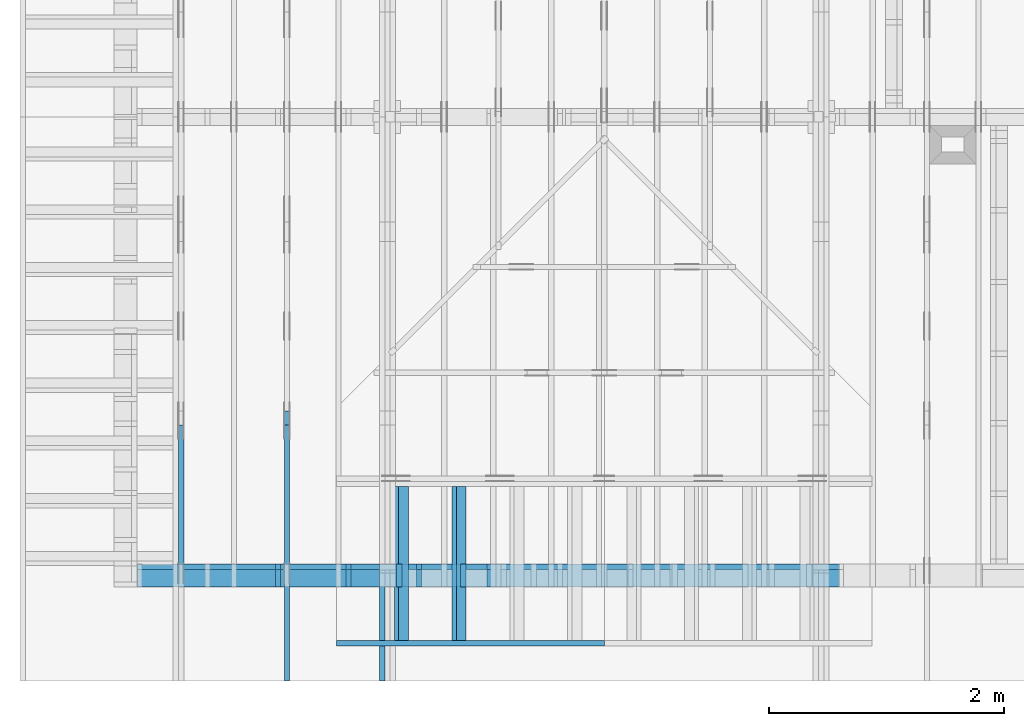
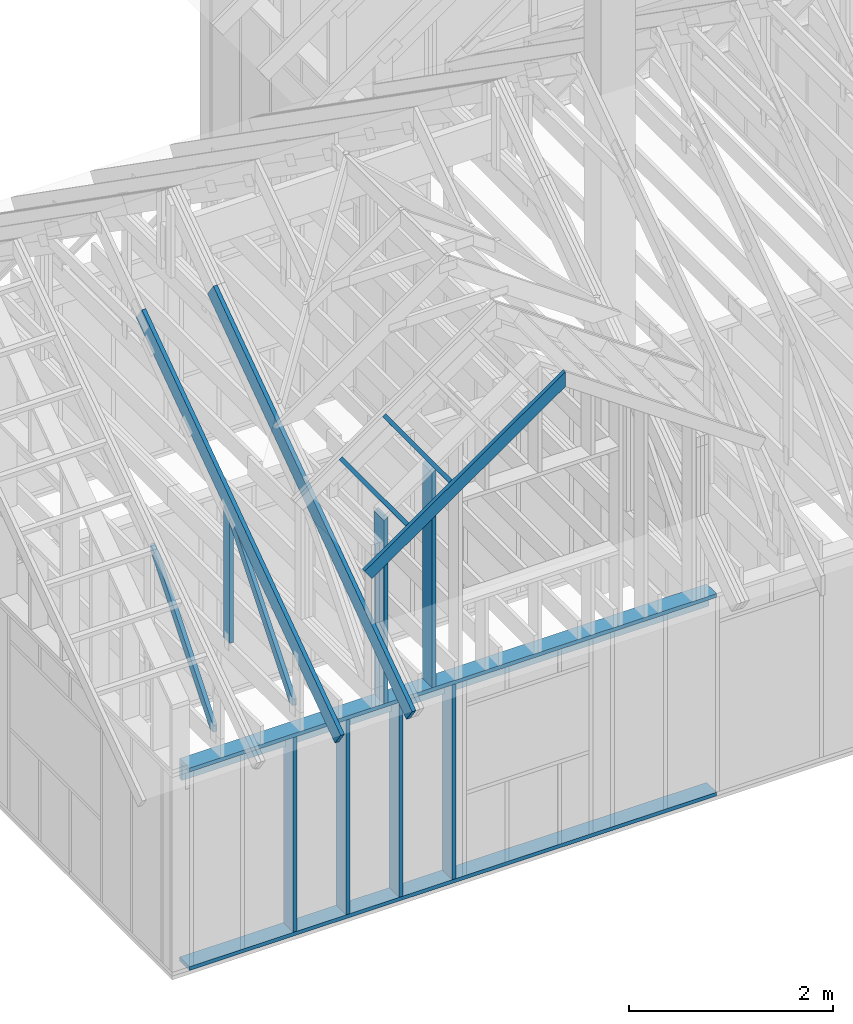
# One storey, part 3 of 70: 17 members, 6 elements without a shape of their own.
"""IFC2X3 building model written with IfcOpenShell, lengths in millimetres."""

from ifc_helpers import new_model, si_unit, frame, origin, origin_with_axes, origin_2d, place, context, project, spatial, faceted_brep, element, aggregate, save


model = new_model("IFC2X3")

# Units and contexts
model_context = context("Model", 3, precision=1e-05, world=origin())
plan_context = context("Plan", 2, precision=1e-05, world=origin_2d())
ifc_project = project(units=[si_unit("LENGTHUNIT", "METRE", prefix="MILLI"), si_unit("AREAUNIT", "SQUARE_METRE"), si_unit("VOLUMEUNIT", "CUBIC_METRE"), si_unit("SOLIDANGLEUNIT", "STERADIAN"), si_unit("PLANEANGLEUNIT", "RADIAN"), si_unit("MASSUNIT", "GRAM"), si_unit("TIMEUNIT", "SECOND"), si_unit("THERMODYNAMICTEMPERATUREUNIT", "DEGREE_CELSIUS"), si_unit("LUMINOUSINTENSITYUNIT", "LUMEN")], contexts=[model_context, plan_context])

# Site, building, storey
site_placement = place(None, origin_with_axes())
site = spatial("IfcSite", under=ifc_project, at=site_placement, CompositionType="ELEMENT")
building_placement = place(site_placement, origin_with_axes())
building = spatial("IfcBuilding", under=site, at=building_placement, Name="Layout 1", CompositionType="ELEMENT")
storey_placement = place(building_placement, origin_with_axes())
storey = spatial("IfcBuildingStorey", under=building, at=storey_placement, Name="Storey 1", CompositionType="ELEMENT", Elevation=0.0)

# Assembly, member
assembly_1_placement = place(storey_placement, frame((1969.9999999999982, 8000.000000000001, 1.1021457184401395e-14), z_axis=(-1.0, 1.836909530733566e-16, 6.123031769111886e-17), x_axis=(-1.836909530733566e-16, -1.0, 0.0)))
assembly_1 = element("IfcElementAssembly", 1, at=assembly_1_placement, inside=storey, Name="T11", AssemblyPlace="FACTORY", PredefinedType="TRUSS")
member_1_placement = place(assembly_1_placement, frame((4782.309641268, 3014.9999999994516, -90.00000000000001), z_axis=(0.0, 0.0, 1.0), x_axis=(0.8191520442889916, -0.5735764363510465, 0.0)))
member_1 = element("IfcMember", 2, at=member_1_placement, Name="T9", context=model_context, shape_type="Brep", body=[
    faceted_brep([(4768.153825500908, 195.00000000180353, 45.0), (1.6370904631912708e-10, 195.00000000180353, 45.0), (0.0, 1.8071659724228084e-09, 45.0), (4768.153825500287, 1.8071659724228084e-09, 45.0), (1.6370904631912708e-10, 195.00000000180353, 2.004791383006049e-26), (4768.153825500908, 195.00000000180353, 5.839111470710887e-13), (4768.153825500287, 1.8071659724228084e-09, 5.839111470710126e-13), (0.0, 1.8071659724228084e-09, 0.0), (-1.2523674699591298e-25, 1.8071659724228084e-09, 7.668285805162028e-42), (2.755364295975112e-15, 1.8071659724228084e-09, 45.0), (1.636957134777711e-10, 195.000000001015, 45.0), (1.63692958113475e-10, 195.000000001015, 9.850859431565386e-31), (4768.153825500287, -2.042652045517506e-12, 1.250722336794479e-28), (4768.153825500287, -2.039896681221406e-12, 45.0), (1.0454840658689129e-27, 1.8071687277871045e-09, 45.0), (0.0, 1.8071659724228084e-09, 0.0), (4768.153825500287, 195.00000000180353, -3.8067271842345146e-26), (4768.153825500287, 195.00000000180353, 45.0), (4768.153825500287, 0.0, 45.0), (4768.153825500287, 0.0, 0.0), (1.6370904631912708e-10, 195.000000001015, 0.0), (1.6370904631912708e-10, 195.000000001015, 45.0), (4768.153825500908, 195.00000000180347, 45.0), (4768.153825500908, 195.00000000180347, -4.733165431326071e-30)], [[[0, 1, 2, 3]], [[4, 5, 6, 7]], [[8, 9, 10, 11]], [[12, 13, 14, 15]], [[16, 17, 18, 19]], [[20, 21, 22, 23]]]),
])
aggregate(assembly_1, [member_1])

assembly_2_placement = place(storey_placement, frame((304.9999999999989, 8000.000000000001, 1.3776821480501744e-15), z_axis=(-1.0, 1.836909530733566e-16, 6.123031769111886e-17), x_axis=(-1.836909530733566e-16, -1.0, 0.0)))
assembly_2 = element("IfcElementAssembly", 3, at=assembly_2_placement, inside=storey, Name="T2", AssemblyPlace="FACTORY", PredefinedType="TRUSS")
member_2_placement = place(assembly_2_placement, frame((6583.248845012375, 1698.1421260061566, -45.00000000000001), z_axis=(0.0, 0.0, 1.0), x_axis=(0.6335417245359882, -0.7737085260432164, 0.0)))
member_2 = element("IfcMember", 4, at=member_2_placement, Name="W7", context=model_context, shape_type="Brep", body=[
    faceted_brep([(1891.3495332787188, 95.00000000000091, 45.0), (169.12158093146445, 95.00000000000091, 45.0), (0.0, 47.4999999999518, 45.0), (58.00905222766687, 0.0, 45.0), (1910.4637938597489, 0.0, 45.0), (1949.3585855061046, 47.4999999999518, 45.0), (169.12158093146445, 95.00000000000091, 2.0710736257715677e-14), (1891.3495332787188, 95.00000000000091, 2.316158655752107e-13), (1949.3585855061046, 47.4999999999518, 2.3871969096889775e-13), (1910.4637938597489, 0.0, 2.339566100708253e-13), (58.00905222766687, 0.0, 7.103825393721498e-15), (0.0, 47.4999999999518, 0.0), (-1.7763568394002505e-15, 47.4999999999518, 0.0), (-1.7763568394002505e-15, 47.4999999999518, 45.0), (169.12158093146445, 94.9999999999991, 45.0), (169.12158093146445, 94.9999999999991, 7.888609052210118e-31), (58.009052227666864, -1.0658141036401503e-14, 7.888609052210118e-31), (58.009052227666864, -7.105427357601002e-15, 45.0), (7.105427357601002e-15, 47.49999999995181, 45.0), (7.105427357601002e-15, 47.49999999995181, -7.888609052210118e-31), (1910.4637938597489, 1.2889367027916569e-12, 3.24552952602152e-29), (1910.4637938597489, 1.2916920670877572e-12, 45.0), (58.00905222766687, -1.3339080885373479e-14, 45.0), (58.00905222766687, -1.6094445181473828e-14, 9.854679915239394e-31), (1949.3585855061056, 47.50000000000102, 6.310887241768094e-29), (1949.3585855061056, 47.50000000000102, 45.0), (1910.4637938597493, 9.094947017729282e-13, 45.0), (1910.4637938597493, 9.094947017729282e-13, 6.310887241768094e-29), (1891.3495332787193, 95.00000000000114, 2.524354896707238e-29), (1891.3495332787193, 95.00000000000114, 45.0), (1949.358585506105, 47.500000000002046, 45.0), (1949.358585506105, 47.500000000002046, 2.524354896707238e-29), (169.12158093146445, 94.99999999999908, 0.0), (169.12158093146445, 94.99999999999908, 45.0), (1891.3495332787188, 95.00000000000088, 45.0), (1891.3495332787188, 95.0000000000009, -1.5777218104420236e-30)], [[[0, 1, 2, 3, 4, 5]], [[6, 7, 8, 9, 10, 11]], [[12, 13, 14, 15]], [[16, 17, 18, 19]], [[20, 21, 22, 23]], [[24, 25, 26, 27]], [[28, 29, 30, 31]], [[32, 33, 34, 35]]]),
])
aggregate(assembly_2, [member_2])

# Assembly, members
assembly_3_placement = place(storey_placement, frame((1204.9999999999989, 8000.000000000001, 1.3776821480501744e-15), z_axis=(-1.0, 1.836909530733566e-16, 6.123031769111886e-17), x_axis=(-1.836909530733566e-16, -1.0, 0.0)))
assembly_3 = element("IfcElementAssembly", 5, at=assembly_3_placement, inside=storey, Name="T2", AssemblyPlace="FACTORY", PredefinedType="TRUSS")
member_3_placement = place(assembly_3_placement, frame((4782.309641268, 3014.9999999994516, -45.00000000000001), z_axis=(0.0, 0.0, 1.0), x_axis=(0.8191520442889916, -0.5735764363510465, 0.0)))
member_3 = element("IfcMember", 6, at=member_3_placement, Name="T9", context=model_context, shape_type="Brep", body=[
    faceted_brep([(4768.153825500908, 195.00000000180353, 45.0), (1.6370904631912708e-10, 195.00000000180353, 45.0), (0.0, 1.8071659724228084e-09, 45.0), (4768.153825500287, 1.8071659724228084e-09, 45.0), (1.6370904631912708e-10, 195.00000000180353, 2.004791383006049e-26), (4768.153825500908, 195.00000000180353, 5.839111470710887e-13), (4768.153825500287, 1.8071659724228084e-09, 5.839111470710126e-13), (0.0, 1.8071659724228084e-09, 0.0), (-1.2523674699591298e-25, 1.8071659724228084e-09, 7.668285805162028e-42), (2.755364295975112e-15, 1.8071659724228084e-09, 45.0), (1.636957134777711e-10, 195.000000001015, 45.0), (1.63692958113475e-10, 195.000000001015, 9.850859431565386e-31), (4768.153825500287, -2.042652045517506e-12, 1.250722336794479e-28), (4768.153825500287, -2.039896681221406e-12, 45.0), (1.0454840658689129e-27, 1.8071687277871045e-09, 45.0), (0.0, 1.8071659724228084e-09, 0.0), (4768.153825500287, 195.00000000180353, -3.8067271842345146e-26), (4768.153825500287, 195.00000000180353, 45.0), (4768.153825500287, 0.0, 45.0), (4768.153825500287, 0.0, 0.0), (1.6370904631912708e-10, 195.000000001015, 0.0), (1.6370904631912708e-10, 195.000000001015, 45.0), (4768.153825500908, 195.00000000180347, 45.0), (4768.153825500908, 195.00000000180347, -4.733165431326071e-30)], [[[0, 1, 2, 3]], [[4, 5, 6, 7]], [[8, 9, 10, 11]], [[12, 13, 14, 15]], [[16, 17, 18, 19]], [[20, 21, 22, 23]]]),
])
member_4_placement = place(assembly_3_placement, frame((6619.999999999389, 220.0, -45.0), z_axis=(0.0, 0.0, 1.0), x_axis=(6.123031769111886e-17, 1.0, 0.0)))
member_4 = element("IfcMember", 7, at=member_4_placement, Name="R1", context=model_context, shape_type="Brep", body=[
    faceted_brep([(1592.2602625068248, 120.0, 45.0), (0.0, 120.0, 45.0), (0.0, 1.4551915228366852e-11, 45.0), (1508.235357921585, 1.4551915228366852e-11, 45.0), (0.0, 120.0, 0.0), (1592.2602625068248, 120.0, 1.949892034404744e-13), (1508.235357921585, 1.4551915228366852e-11, 1.8469946023703405e-13), (0.0, 1.4551915228366852e-11, 0.0), (1.7820367848942657e-27, 1.4551915228366852e-11, -1.0911467847633593e-43), (2.755364296102131e-15, 1.4551915228366852e-11, 45.0), (1.7450640541968876e-14, 120.0, 45.0), (1.4695276245868527e-14, 120.0, -8.997964330932825e-31), (1508.235357921585, -4.605370260698061e-13, 2.81988284147774e-29), (1508.235357921585, -4.577816617737058e-13, 45.0), (2.7425941661909085e-29, 1.4554670592662952e-11, 45.0), (0.0, 1.4551915228366852e-11, 0.0), (1592.260262506825, 120.00000000000011, 1.262177448353619e-29), (1592.260262506825, 120.00000000000011, 45.0), (1508.2353579215853, 0.0, 45.0), (1508.2353579215853, 0.0, 1.262177448353619e-29), (0.0, 120.0, 0.0), (-1.6871183120499046e-31, 120.0, 45.0), (1592.2602625068248, 119.9999999999999, 45.0), (1592.2602625068248, 119.9999999999999, -6.310887241768095e-30)], [[[0, 1, 2, 3]], [[4, 5, 6, 7]], [[8, 9, 10, 11]], [[12, 13, 14, 15]], [[16, 17, 18, 19]], [[20, 21, 22, 23]]]),
])
member_5_placement = place(assembly_3_placement, frame((6583.248845012375, 1698.1421260061566, -45.00000000000001), z_axis=(0.0, 0.0, 1.0), x_axis=(0.6335417245359882, -0.7737085260432164, 0.0)))
member_5 = element("IfcMember", 8, at=member_5_placement, Name="W7", context=model_context, shape_type="Brep", body=[
    faceted_brep([(1891.3495332787188, 95.00000000000091, 45.0), (169.12158093146445, 95.00000000000091, 45.0), (0.0, 47.4999999999518, 45.0), (58.00905222766687, 0.0, 45.0), (1910.4637938597489, 0.0, 45.0), (1949.3585855061046, 47.4999999999518, 45.0), (169.12158093146445, 95.00000000000091, 2.0710736257715677e-14), (1891.3495332787188, 95.00000000000091, 2.316158655752107e-13), (1949.3585855061046, 47.4999999999518, 2.3871969096889775e-13), (1910.4637938597489, 0.0, 2.339566100708253e-13), (58.00905222766687, 0.0, 7.103825393721498e-15), (0.0, 47.4999999999518, 0.0), (-1.7763568394002505e-15, 47.4999999999518, 0.0), (-1.7763568394002505e-15, 47.4999999999518, 45.0), (169.12158093146445, 94.9999999999991, 45.0), (169.12158093146445, 94.9999999999991, 7.888609052210118e-31), (58.009052227666864, -1.0658141036401503e-14, 7.888609052210118e-31), (58.009052227666864, -7.105427357601002e-15, 45.0), (7.105427357601002e-15, 47.49999999995181, 45.0), (7.105427357601002e-15, 47.49999999995181, -7.888609052210118e-31), (1910.4637938597489, 1.2889367027916569e-12, 3.24552952602152e-29), (1910.4637938597489, 1.2916920670877572e-12, 45.0), (58.00905222766687, -1.3339080885373479e-14, 45.0), (58.00905222766687, -1.6094445181473828e-14, 9.854679915239394e-31), (1949.3585855061056, 47.50000000000102, 6.310887241768094e-29), (1949.3585855061056, 47.50000000000102, 45.0), (1910.4637938597493, 9.094947017729282e-13, 45.0), (1910.4637938597493, 9.094947017729282e-13, 6.310887241768094e-29), (1891.3495332787193, 95.00000000000114, 2.524354896707238e-29), (1891.3495332787193, 95.00000000000114, 45.0), (1949.358585506105, 47.500000000002046, 45.0), (1949.358585506105, 47.500000000002046, 2.524354896707238e-29), (169.12158093146445, 94.99999999999908, 0.0), (169.12158093146445, 94.99999999999908, 45.0), (1891.3495332787188, 95.00000000000088, 45.0), (1891.3495332787188, 95.0000000000009, -1.5777218104420236e-30)], [[[0, 1, 2, 3, 4, 5]], [[6, 7, 8, 9, 10, 11]], [[12, 13, 14, 15]], [[16, 17, 18, 19]], [[20, 21, 22, 23]], [[24, 25, 26, 27]], [[28, 29, 30, 31]], [[32, 33, 34, 35]]]),
])
aggregate(assembly_3, [member_3, member_4, member_5])

assembly_4_placement = place(storey_placement, frame((-48.55339059325575, 0.0, -2470.0), z_axis=(0.0, -1.0, 6.123031769111886e-17), x_axis=(1.0, 0.0, 0.0)))
assembly_4 = element("IfcElementAssembly", 9, at=assembly_4_placement, inside=storey, Name="VE4", AssemblyPlace="FACTORY", PredefinedType="NOTDEFINED")
member_6_placement = place(assembly_4_placement, frame((1.457281561048629e-13, 2425.0, -195.0), z_axis=(0.0, 0.0, 1.0), x_axis=(1.0, 0.0, 0.0)))
member_6 = element("IfcMember", 10, at=member_6_placement, Name="P1", context=model_context, shape_type="Brep", body=[
    faceted_brep([(5980.000000000002, 45.0, 195.0), (2.755364296100349e-15, 45.0, 195.0), (0.0, 0.0, 195.0), (5980.000000000002, 0.0, 195.0), (2.755364296100349e-15, 45.0, 3.3742366240998092e-31), (5980.000000000002, 45.0, 7.323145995857818e-13), (5980.000000000002, 0.0, 7.323145995857818e-13), (0.0, 0.0, 0.0), (0.0, 0.0, 0.0), (1.1939911949768178e-14, -1.462169203776584e-30, 195.0), (1.7450640541968876e-14, 45.0, 195.0), (5.510728592200698e-15, 45.0, -1.6871183120499046e-31), (5980.000000000002, -1.0984718993786728e-12, 6.725978337372289e-29), (5980.000000000002, -1.0865319874289046e-12, 195.0), (2.193253805664876e-30, 1.1939911949768178e-14, 195.0), (0.0, 0.0, 0.0), (5980.000000000002, 45.0, 0.0), (5980.000000000002, 45.0, 195.0), (5980.000000000002, 0.0, 195.0), (5980.000000000002, 0.0, 0.0), (2.755364296100349e-15, 45.0, 0.0), (2.755364296100348e-15, 44.999999999999986, 195.0), (5980.000000000002, 44.99999999999962, 195.0), (5980.000000000002, 44.99999999999963, -2.2482535798798836e-29)], [[[0, 1, 2, 3]], [[4, 5, 6, 7]], [[8, 9, 10, 11]], [[12, 13, 14, 15]], [[16, 17, 18, 19]], [[20, 21, 22, 23]]]),
])
member_7_placement = place(assembly_4_placement, frame((5980.0, 90.0, -195.0), z_axis=(0.0, 0.0, 1.0), x_axis=(-1.0, 1.2246063538223773e-16, 0.0)))
member_7 = element("IfcMember", 11, at=member_7_placement, Name="P1", context=model_context, shape_type="Brep", body=[
    faceted_brep([(5980.0, 45.00000000000074, 195.0), (0.0, 45.00000000000074, 195.0), (0.0, 0.0, 195.0), (5980.0, 0.0, 195.0), (0.0, 45.00000000000074, 0.0), (5980.0, 45.00000000000074, 7.323145995857816e-13), (5980.0, 0.0, 7.323145995857816e-13), (0.0, 0.0, 0.0), (0.0, 0.0, 0.0), (1.1939911949768178e-14, -1.462169203776584e-30, 195.0), (1.7450640541968876e-14, 45.00000000000001, 195.0), (5.5107285922006985e-15, 45.00000000000001, -3.3742366240998097e-31), (5980.0, -1.0984718993786724e-12, 1.1250681111517883e-28), (5980.0, -1.0865319874289042e-12, 195.0), (2.193253805664876e-30, 1.1939911949768178e-14, 195.0), (0.0, 0.0, 0.0), (5980.0, 45.00000000000074, 0.0), (5980.0, 45.00000000000074, 195.0), (5980.0, 7.389644451905042e-13, 195.0), (5980.0, 7.389644451905042e-13, 0.0), (0.0, 45.00000000000001, 0.0), (1.5777218104420236e-30, 44.99999999999999, 195.0), (5980.0, 45.00000000000096, 195.0), (5980.0, 45.000000000000966, 1.3805065841367707e-29)], [[[0, 1, 2, 3]], [[4, 5, 6, 7]], [[8, 9, 10, 11]], [[12, 13, 14, 15]], [[16, 17, 18, 19]], [[20, 21, 22, 23]]]),
])
member_8_placement = place(assembly_4_placement, frame((1.3378824415499132e-13, 2229.9999999981374, -195.0), z_axis=(0.0, 0.0, 1.0), x_axis=(1.0, 0.0, 0.0)))
member_8 = element("IfcMember", 12, at=member_8_placement, Name="L1", context=model_context, shape_type="Brep", body=[
    faceted_brep([(5980.000000000002, 195.00000000186265, 45.0), (1.1939911949871576e-14, 195.00000000186265, 45.0), (0.0, 0.0, 45.0), (5980.000000000002, 0.0, 45.0), (1.1939911949871576e-14, 195.00000000186265, 1.4621692037892461e-30), (5980.000000000002, 195.00000000186265, 7.323145995857818e-13), (5980.000000000002, 0.0, 7.323145995857818e-13), (0.0, 0.0, 0.0), (0.0, 0.0, 0.0), (2.755364296100349e-15, -3.3742366240998092e-31, 45.0), (2.6635188195864806e-14, 195.00000000186265, 45.0), (2.3879823899764457e-14, 195.00000000186265, -7.310846018959277e-31), (5980.000000000002, 1.8631702674827906e-09, -3.215315738519505e-29), (5980.000000000002, 1.8631730228470867e-09, 45.0), (-8.584804067855881e-28, 2.755364296100349e-15, 45.0), (0.0, 0.0, 0.0), (5980.000000000002, 195.00000000186265, 0.0), (5980.000000000002, 195.00000000186265, 45.0), (5980.000000000002, 1.862645149230957e-09, 45.0), (5980.000000000002, 1.862645149230957e-09, 0.0), (1.1939911949871576e-14, 195.00000000186265, 0.0), (1.1939911949871576e-14, 195.00000000186265, 45.0), (5980.000000000002, 195.00000000186228, 45.0), (5980.000000000002, 195.00000000186228, -2.208810534618833e-29)], [[[0, 1, 2, 3]], [[4, 5, 6, 7]], [[8, 9, 10, 11]], [[12, 13, 14, 15]], [[16, 17, 18, 19]], [[20, 21, 22, 23]]]),
])
member_9_placement = place(assembly_4_placement, frame((2977.499999992955, 2425.0, -195.0), z_axis=(0.0, 0.0, 1.0), x_axis=(7.044874666267686e-16, -1.0, 0.0)))
member_9 = element("IfcMember", 13, at=member_9_placement, Name="S11", context=model_context, shape_type="Brep", body=[
    faceted_brep([(0.0, 45.00000000000182, 45.0), (195.00000000186265, 45.00000000000182, 45.00000000000002), (195.00000000186265, 1.8189894035458565e-12, 45.00000000000002), (0.0, 1.8189894035458565e-12, 45.0), (195.00000000186265, 1.3642420526593924e-12, 0.0), (195.00000000186265, 1.3642420526593924e-12, 45.0), (195.00000000186265, 45.00000000000273, 45.0), (195.00000000186265, 45.00000000000273, 0.0), (2.7553642961005717e-15, 1.8189894035458565e-12, 45.0), (1.19399119497684e-14, 1.8189894035458565e-12, 195.0), (1.7450640541969097e-14, 45.00000000000182, 195.0), (8.266092888301269e-15, 45.00000000000182, 45.0), (2335.0, -2.757722191880016e-12, 2.8023350496855364e-28), (2335.0, -2.745782279930248e-12, 195.0), (2.340279805947236e-29, 1.8309293154956247e-12, 195.0), (5.400645706032083e-30, 1.821744767841957e-12, 45.0), (195.00000000186265, 1.4395354483059526e-12, 45.0), (195.00000000186265, 1.4367800840098523e-12, -4.441526704277007e-30), (0.0, 45.00000000000318, 45.0), (-2.524354896707238e-29, 45.00000000000317, 195.0), (2335.0, 44.99999999999785, 195.0), (2335.0, 44.999999999997854, -2.9858385262615297e-28), (195.00000000186265, 45.000000000002736, 3.944304526105059e-31), (195.00000000186265, 45.000000000002736, 45.0), (2335.0, 45.00000000001455, 0.0), (2335.0, 45.00000000001455, 195.0), (2335.0, 0.0, 195.0), (2335.0, 0.0, 0.0), (2335.0, 45.00000000001455, 195.0), (0.0, 45.00000000001455, 195.0), (0.0, 1.8189894035458565e-12, 195.0), (2335.0, 1.8189894035458565e-12, 195.0), (195.00000000186265, 45.00000000000273, 2.3879823899764457e-14), (2335.0, 45.00000000000273, 2.859455836175251e-13), (2335.0, 0.0, 2.859455836175251e-13), (195.00000000186265, 0.0, 2.3879823899764457e-14)], [[[0, 1, 2, 3]], [[4, 5, 6, 7]], [[8, 9, 10, 11]], [[12, 13, 14, 15, 16, 17]], [[18, 19, 20, 21, 22, 23]], [[24, 25, 26, 27]], [[28, 29, 30, 31]], [[32, 33, 34, 35]]]),
])
member_10_placement = place(assembly_4_placement, frame((1177.5000000018194, 2425.0, -195.0), z_axis=(0.0, 0.0, 1.0), x_axis=(-1.836909530733566e-16, -1.0, 0.0)))
member_10 = element("IfcMember", 14, at=member_10_placement, Name="S11", context=model_context, shape_type="Brep", body=[
    faceted_brep([(0.0, 44.999999999999545, 45.0), (195.00000000186265, 44.999999999999545, 45.00000000000002), (195.00000000186265, 1.4097167877480388e-11, 45.00000000000002), (0.0, 1.4097167877480388e-11, 45.0), (195.00000000186265, 1.2960299500264227e-11, 0.0), (195.00000000186265, 1.2960299500264227e-11, 45.0), (195.00000000186265, 45.00000000000068, 45.0), (195.00000000186265, 45.00000000000068, 0.0), (2.7553642961020753e-15, 1.4097167877480388e-11, 45.0), (1.1939911949769904e-14, 1.4097167877480388e-11, 195.0), (1.7450640541968822e-14, 44.999999999999545, 195.00000000000003), (8.26609288830099e-15, 44.999999999999545, 45.0), (2335.0, 1.36682495020541e-11, 2.626280839091018e-29), (2335.0, 1.3680189414003868e-11, 195.0), (2.193253805664876e-30, 1.4109107789430156e-11, 195.0), (5.061354936149714e-31, 1.4099923241776488e-11, 45.0), (195.00000000186265, 1.4064103505926841e-11, 45.0), (195.00000000186265, 1.406134814163074e-11, 2.193253805685862e-30), (-1.6871183120499046e-31, 45.00000000000068, 45.0), (-7.31084601888292e-31, 45.00000000000067, 195.0), (2335.0, 45.000000000000526, 195.0), (2335.0, 45.00000000000054, -8.67746995743113e-30), (195.00000000186265, 45.00000000000067, -7.888609052210118e-31), (195.00000000186265, 45.00000000000067, 45.0), (2335.0, 45.00000000001455, 0.0), (2335.0, 45.00000000001455, 195.0), (2335.0, 0.0, 195.0), (2335.0, 0.0, 0.0), (2335.0, 45.00000000001455, 195.0), (0.0, 45.00000000001455, 195.0), (0.0, 1.4097167877480388e-11, 195.0), (2335.0, 1.4097167877480388e-11, 195.0), (195.00000000186265, 45.00000000000068, 2.3879823899764457e-14), (2335.0, 45.00000000000068, 2.859455836175251e-13), (2335.0, 0.0, 2.859455836175251e-13), (195.00000000186265, 0.0, 2.3879823899764457e-14)], [[[0, 1, 2, 3]], [[4, 5, 6, 7]], [[8, 9, 10, 11]], [[12, 13, 14, 15, 16, 17]], [[18, 19, 20, 21, 22, 23]], [[24, 25, 26, 27]], [[28, 29, 30, 31]], [[32, 33, 34, 35]]]),
])
member_11_placement = place(assembly_4_placement, frame((1777.500000001819, 2425.0, -195.0), z_axis=(0.0, 0.0, 1.0), x_axis=(-1.836909530733566e-16, -1.0, 0.0)))
member_11 = element("IfcMember", 15, at=member_11_placement, Name="S11", context=model_context, shape_type="Brep", body=[
    faceted_brep([(0.0, 45.00000000001455, 45.0), (195.00000000186265, 45.00000000001455, 45.00000000000002), (195.00000000186265, 0.0, 45.00000000000002), (0.0, 0.0, 45.0), (195.00000000186265, 0.0, 0.0), (195.00000000186265, -3.3742366240998092e-31, 45.0), (195.00000000186265, 45.00000000001455, 45.0), (195.00000000186265, 45.00000000001455, 0.0), (2.755364296100349e-15, -3.3742366240998092e-31, 45.0), (1.193991194976818e-14, -1.4621692037765842e-30, 195.00000000000003), (1.745064054197066e-14, 45.00000000001455, 195.00000000000003), (8.26609288830283e-15, 45.00000000001455, 45.0), (2335.0, -4.2891837542628763e-13, 2.626280839091018e-29), (2335.0, -4.1697846347651946e-13, 195.0), (2.193253805664876e-30, 1.1939911949768178e-14, 195.0), (5.061354936149714e-31, 2.755364296100349e-15, 45.0), (195.00000000186265, -3.306437155354634e-14, 45.0), (195.00000000186265, -3.5819735849646686e-14, 2.193253805685826e-30), (-1.6871183120499046e-31, 45.00000000001455, 45.0), (-7.31084601888292e-31, 45.00000000001454, 195.0), (2335.0, 45.000000000014396, 195.0), (2335.0, 45.00000000001441, -8.67746995743113e-30), (195.00000000186265, 45.00000000001454, -7.888609052210118e-31), (195.00000000186265, 45.00000000001454, 45.0), (2335.0, 45.00000000001501, 0.0), (2335.0, 45.00000000001501, 195.0), (2335.0, 4.547473508864641e-13, 195.0), (2335.0, 4.547473508864641e-13, 0.0), (2335.0, 45.00000000001501, 195.0), (0.0, 45.00000000001501, 195.0), (0.0, 0.0, 195.0), (2335.0, 0.0, 195.0), (195.00000000186265, 45.00000000001455, 2.3879823899764457e-14), (2335.0, 45.00000000001455, 2.859455836175251e-13), (2335.0, 4.547473508864641e-13, 2.859455836175251e-13), (195.00000000186265, 4.547473508864641e-13, 2.3879823899764457e-14)], [[[0, 1, 2, 3]], [[4, 5, 6, 7]], [[8, 9, 10, 11]], [[12, 13, 14, 15, 16, 17]], [[18, 19, 20, 21, 22, 23]], [[24, 25, 26, 27]], [[28, 29, 30, 31]], [[32, 33, 34, 35]]]),
])
member_12_placement = place(assembly_4_placement, frame((2377.4999999929564, 2425.0, -195.0), z_axis=(0.0, 0.0, 1.0), x_axis=(7.044874666267686e-16, -1.0, 0.0)))
member_12 = element("IfcMember", 16, at=member_12_placement, Name="S11", context=model_context, shape_type="Brep", body=[
    faceted_brep([(0.0, 45.000000000000455, 45.0), (195.00000000186265, 45.000000000000455, 45.00000000000002), (195.00000000186265, 4.547473508864641e-13, 45.00000000000002), (0.0, 4.547473508864641e-13, 45.0), (195.00000000186265, 1.3642420526593924e-12, 0.0), (195.00000000186265, 1.3642420526593924e-12, 45.0), (195.00000000186265, 45.0, 45.0), (195.00000000186265, 45.0, 0.0), (2.7553642961004044e-15, 4.547473508864641e-13, 45.0), (1.1939911949768233e-14, 4.547473508864641e-13, 195.0), (1.7450640541968933e-14, 45.000000000000455, 195.0), (8.266092888301103e-15, 45.000000000000455, 45.0), (2335.0, -4.121964244539408e-12, 2.8023350496855364e-28), (2335.0, -4.11002433258964e-12, 195.0), (2.340279805947236e-29, 4.666872628362323e-13, 195.0), (5.400645706032083e-30, 4.575027151825645e-13, 45.0), (195.00000000186265, 7.529339564656022e-14, 45.0), (195.00000000186265, 7.253803135045987e-14, -4.441526704276998e-30), (0.0, 45.000000000000455, 45.0), (-2.524354896707238e-29, 45.00000000000044, 195.0), (2335.0, 44.99999999999512, 195.0), (2335.0, 44.999999999995126, -2.9818942217354246e-28), (195.00000000186265, 45.00000000000001, 7.888609052210118e-31), (195.00000000186265, 45.00000000000001, 45.0), (2335.0, 44.999999999998636, 2.842170943040401e-14), (2335.0, 44.999999999998636, 195.0), (2335.0, 1.318767317570746e-11, 195.0), (2335.0, 1.318767317570746e-11, 0.0), (2335.0, 44.999999999998636, 195.0), (0.0, 44.999999999998636, 195.0), (0.0, 4.547473508864641e-13, 195.0), (2335.0, 4.547473508864641e-13, 195.0), (195.00000000186265, 45.0, 2.3879823899764457e-14), (2335.0, 45.0, 2.859455836175251e-13), (2335.0, 1.318767317570746e-11, 2.859455836175251e-13), (195.00000000186265, 1.318767317570746e-11, 2.3879823899764457e-14)], [[[0, 1, 2, 3]], [[4, 5, 6, 7]], [[8, 9, 10, 11]], [[12, 13, 14, 15, 16, 17]], [[18, 19, 20, 21, 22, 23]], [[24, 25, 26, 27]], [[28, 29, 30, 31]], [[32, 33, 34, 35]]]),
])
aggregate(assembly_4, [member_6, member_7, member_8, member_9, member_10, member_11, member_12])

assembly_5_placement = place(storey_placement, frame((5705.000000000031, 195.0, 0.0), z_axis=(1.2246063538223773e-16, 1.0, 6.123031769111886e-17), x_axis=(-1.0, 1.2246063538223773e-16, 0.0)))
assembly_5 = element("IfcElementAssembly", 17, at=assembly_5_placement, inside=storey, Name="VEg2", AssemblyPlace="FACTORY", PredefinedType="NOTDEFINED")
member_13_placement = place(assembly_5_placement, frame((3500.0, 2226.5642427364364, -195.0), z_axis=(0.0, 0.0, 1.0), x_axis=(-1.836909530733566e-16, -1.0, 0.0)))
member_13 = element("IfcMember", 18, at=member_13_placement, Name="S11", context=model_context, shape_type="Brep", body=[
    faceted_brep([(2226.5642427364364, 45.000000000000455, 195.0), (31.509339219890535, 45.000000000000455, 195.0), (0.0, 0.0, 195.0), (2226.5642427364364, 0.0, 195.0), (31.509339219890535, 45.000000000000455, 3.858653701342258e-15), (2226.5642427364364, 45.000000000000455, 2.72666471884875e-13), (2226.5642427364364, 0.0, 2.72666471884875e-13), (0.0, 0.0, 0.0), (-2.910212672749112e-15, 2.0377528512816902e-15, 2.175337872185383e-31), (6.870390609487732e-15, -4.810699295277764e-15, 195.0), (31.509339219890542, 44.999999999999986, 195.0), (31.50933921989053, 44.99999999999999, 2.175337872185383e-31), (2226.5642427364364, -4.0899970782731247e-13, 5.288750680981404e-29), (2226.5642427364364, -3.970597958775443e-13, 195.0), (2.193253805664876e-30, 1.1939911949768178e-14, 195.0), (0.0, 0.0, 0.0), (2226.5642427364364, 45.000000000000455, 0.0), (2226.5642427364364, 45.000000000000455, 195.0), (2226.5642427364364, 4.547473508864641e-13, 195.0), (2226.5642427364364, 4.547473508864641e-13, 0.0), (31.509339219890535, 45.0, 0.0), (31.509339219890535, 44.999999999999986, 195.0), (2226.5642427364364, 45.00000000000034, 195.0), (2226.5642427364364, 45.00000000000035, -6.310887241768095e-30)], [[[0, 1, 2, 3]], [[4, 5, 6, 7]], [[8, 9, 10, 11]], [[12, 13, 14, 15]], [[16, 17, 18, 19]], [[20, 21, 22, 23]]]),
])
member_14_placement = place(assembly_5_placement, frame((2955.0000000000005, 2608.177351060949, -195.0), z_axis=(0.0, 0.0, 1.0), x_axis=(-1.836909530733566e-16, -1.0, 0.0)))
member_14 = element("IfcMember", 19, at=member_14_placement, Name="S9", context=model_context, shape_type="Brep", body=[
    faceted_brep([(2608.177351060949, 45.0, 195.0), (31.50933921932301, 45.0, 195.0), (0.0, 2.298747858731076e-09, 195.0), (2608.177351060949, 2.298747858731076e-09, 195.0), (31.50933921932301, 45.0, 3.858653701272758e-15), (2608.177351060949, 45.0, 3.1939905560048555e-13), (2608.177351060949, 2.298747858731076e-09, 3.1939905560048555e-13), (0.0, 2.298747858731076e-09, 0.0), (-2.9865859521065925e-16, 2.2987480678540764e-09, 2.2324256885101844e-32), (9.481944686981758e-15, 2.2987412194019297e-09, 195.0), (31.509339219323028, 45.00000000229875, 195.0), (31.509339219323017, 45.000000002298755, -2.9339913517667076e-31), (2608.177351060949, 2.7413688840655613e-13, -1.6785488767995798e-29), (2608.177351060949, 2.860768003563243e-13, 195.0), (1.0522127203799236e-26, 2.298759798643026e-09, 195.0), (0.0, 2.298747858731076e-09, 0.0), (2608.177351060949, 45.0, 0.0), (2608.177351060949, 45.0, 195.0), (2608.177351060949, 0.0, 195.0), (2608.177351060949, 0.0, 0.0), (31.50933921932301, 45.00000000229874, 0.0), (31.50933921932301, 45.000000002298734, 195.0), (2608.177351060949, 44.99999999999974, 195.0), (2608.177351060949, 44.999999999999744, -1.538278765180973e-29)], [[[0, 1, 2, 3]], [[4, 5, 6, 7]], [[8, 9, 10, 11]], [[12, 13, 14, 15]], [[16, 17, 18, 19]], [[20, 21, 22, 23]]]),
])
aggregate(assembly_5, [member_13, member_14])

assembly_6_placement = place(storey_placement, frame((1649.9999999999977, -500.00000000000045, 2069.8962308951445), z_axis=(-0.5735764363510462, -1.1073377781974426e-17, 0.8191520442889918), x_axis=(0.8191520442889918, 3.5120267417914375e-17, 0.5735764363510462)))
assembly_6 = element("IfcElementAssembly", 20, at=assembly_6_placement, inside=storey, Name="gs6", AssemblyPlace="FACTORY", PredefinedType="TRUSS")
member_15_placement = place(assembly_6_placement, frame((2780.314125904217, 45.0, -145.00000000000134), z_axis=(0.0, 0.0, 1.0), x_axis=(-1.0, 1.2246063538223773e-16, 0.0)))
member_15 = element("IfcMember", 21, at=member_15_placement, Name="T6", context=model_context, shape_type="Brep", body=[
    faceted_brep([(101.53009304084028, -1.2433439704199015e-14, 1.4210854715202004e-14), (-1.4210854715202004e-14, 3.734987395653177e-30, 145.0000000000013), (-1.4210854715202004e-14, 45.0, 145.0000000000013), (101.53009304084028, 44.999999999999986, 2.842170943040401e-14), (2780.314125904213, -5.107185516306612e-13, 1.3358203432289883e-12), (2780.314125904213, -5.01840155565449e-13, 145.00000000000134), (1.6308810349815895e-30, 8.878396065212317e-15, 145.00000000000134), (101.53009304084208, -1.8650159556298767e-14, 1.3358203432289883e-12), (101.53009304084208, 45.000000000000014, 1.3482537829331875e-12), (2780.314125904217, 45.000000000000014, 1.6762993776494297e-12), (2780.314125904213, 3.410605131648481e-13, 1.6762993776494293e-12), (101.53009304084208, 3.410605131648481e-13, 1.3482537829331875e-12), (-5.436270116605298e-31, 45.00000000000001, 145.00000000000134), (2780.314125904217, 44.99999999999984, 145.00000000000134), (2780.314125904217, 44.999999999999844, 1.3358203432289883e-12), (101.53009304084208, 45.00000000000001, 1.3358203432289883e-12), (2780.314125904213, 45.00000000000034, 1.3642420526593922e-12), (2780.314125904213, 45.00000000000034, 145.00000000000134), (2780.314125904213, 3.481659405224491e-13, 145.00000000000134), (2780.314125904213, 3.481659405224491e-13, 1.3358203432289883e-12), (2780.314125904217, 45.00000000000034, 145.00000000000134), (0.0, 45.00000000000034, 145.00000000000134), (0.0, 0.0, 145.00000000000134), (2780.314125904213, 0.0, 145.00000000000134)], [[[0, 1, 2, 3]], [[4, 5, 6, 7]], [[8, 9, 10, 11]], [[12, 13, 14, 15]], [[16, 17, 18, 19]], [[20, 21, 22, 23]]]),
])
member_16_placement = place(assembly_6_placement, frame((644.9999999994907, 44.99999999999999, -145.0), z_axis=(0.0, 0.0, 1.0), x_axis=(6.123031769111886e-17, 1.0, 0.0)))
member_16 = element("IfcMember", 22, at=member_16_placement, Name="W3", context=model_context, shape_type="Brep", body=[
    faceted_brep([(1310.0000000000002, 45.000000000000114, 145.0), (0.0, 45.000000000000114, 145.0), (7.105427357601002e-15, 0.0, 145.0), (1310.0000000000002, 0.0, 145.0), (0.0, 45.000000000000114, 0.0), (1310.0000000000002, 45.000000000000114, 1.6042343235073145e-13), (1310.0000000000002, 0.0, 1.6042343235073145e-13), (7.105427357601002e-15, 0.0, 8.701351488741532e-31), (7.105427357601002e-15, 0.0, 0.0), (1.5983823422813237e-14, -1.0872540233210496e-30, 145.0), (2.1494552015013935e-14, 45.0, 145.0), (1.26161559498017e-14, 45.0, -7.724912368470575e-31), (1310.0000000000002, -2.406351485260972e-13, 2.1695247782895728e-29), (1310.0000000000002, -2.3175675246088495e-13, 145.0), (7.105427357601003e-15, 8.878396065212234e-15, 145.0), (7.105427357601002e-15, -1.9218390339572725e-30, 1.1767481460039678e-46), (1310.0000000000002, 45.000000000000114, 0.0), (1310.0000000000002, 45.000000000000114, 145.0), (1310.0000000000002, 1.1368683772161603e-13, 145.0), (1310.0000000000002, 1.1368683772161603e-13, 0.0), (0.0, 45.0, 0.0), (1.5777218104420236e-30, 44.99999999999999, 145.0), (1310.0000000000002, 45.0000000000002, 145.0), (1310.0000000000002, 45.00000000000021, 5.9164567891575885e-30)], [[[0, 1, 2, 3]], [[4, 5, 6, 7]], [[8, 9, 10, 11]], [[12, 13, 14, 15]], [[16, 17, 18, 19]], [[20, 21, 22, 23]]]),
])
member_17_placement = place(assembly_6_placement, frame((1244.9999999994907, 44.99999999999999, -145.0), z_axis=(0.0, 0.0, 1.0), x_axis=(6.123031769111886e-17, 1.0, 0.0)))
member_17 = element("IfcMember", 23, at=member_17_placement, Name="W3", context=model_context, shape_type="Brep", body=[
    faceted_brep([(1310.0000000000002, 45.0, 145.0), (0.0, 45.0, 145.0), (7.105427357601002e-15, 1.4551915228366852e-11, 145.0), (1310.0000000000002, 1.4551915228366852e-11, 145.0), (0.0, 45.0, 0.0), (1310.0000000000002, 45.0, 1.6042343235073145e-13), (1310.0000000000002, 1.4551915228366852e-11, 1.6042343235073145e-13), (7.105427357601002e-15, 1.4551915228366852e-11, 8.701351488741532e-31), (7.105427357605082e-15, 1.4551915228366852e-11, -2.4986903241991894e-43), (1.598382342281732e-14, 1.4551915228366852e-11, 145.0), (2.1494552015018018e-14, 45.00000000001455, 145.0), (1.261615594980578e-14, 45.00000000001455, -7.724912368473074e-31), (1310.0000000000002, 3.491153221547828e-13, -2.1376442086374676e-29), (1310.0000000000002, 3.5799371821999503e-13, 145.0), (7.105427357601098e-15, 1.4560793624432064e-11, 145.0), (7.105427357601002e-15, 1.4551915228366852e-11, 0.0), (1310.0000000000002, 45.0, 0.0), (1310.0000000000002, 45.0, 145.0), (1310.0000000000002, 0.0, 145.0), (1310.0000000000002, 0.0, 0.0), (0.0, 45.00000000001455, 0.0), (-1.0097419586828951e-28, 45.000000000014545, 145.0), (1310.0000000000002, 44.99999999999992, 145.0), (1310.0000000000002, 44.99999999999993, -4.338734978715565e-30)], [[[0, 1, 2, 3]], [[4, 5, 6, 7]], [[8, 9, 10, 11]], [[12, 13, 14, 15]], [[16, 17, 18, 19]], [[20, 21, 22, 23]]]),
])
aggregate(assembly_6, [member_15, member_16, member_17])

save(model, "model.ifc")
